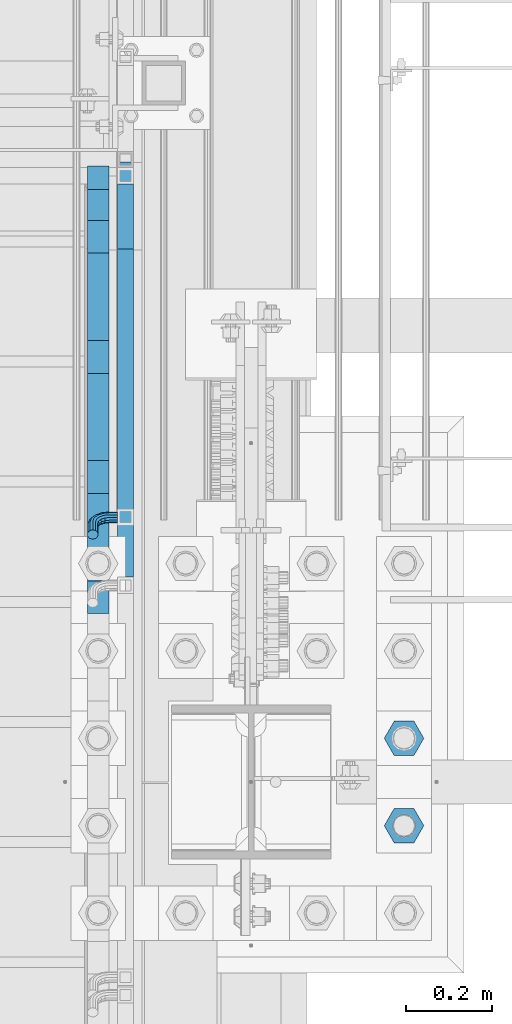
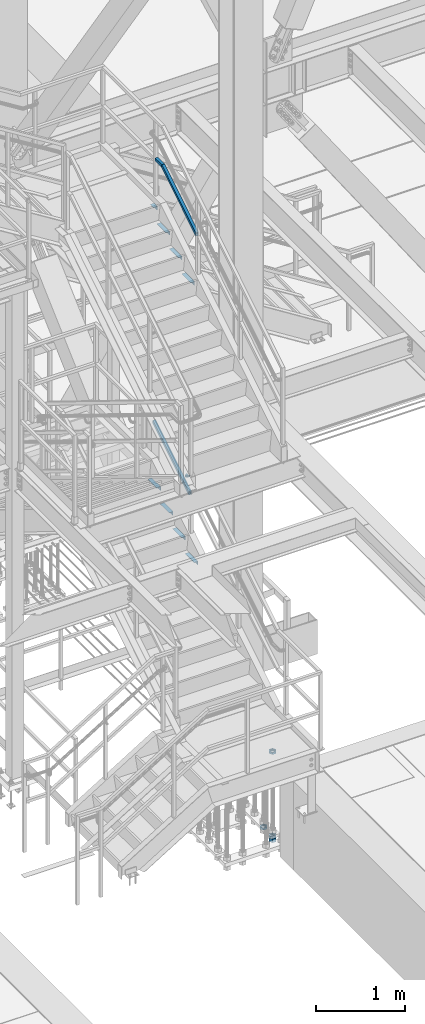
# One storey, part 2094 of 3843: 14 beams, 2 members, 5 elements without a shape of their own.
"""IFC2X3 building model written with IfcOpenShell, lengths in millimetres."""

from ifc_helpers import new_model, si_unit, frame, origin_with_axes, place, context, subcontext, project, spatial, faceted_brep, material, type_object, element, aggregate, save


model = new_model("IFC2X3")

# Units and contexts
model_context = context("Model", 3, precision=1e-05, world=origin_with_axes())
body_context = subcontext(model_context, "Body", "Model", "MODEL_VIEW")
ifc_project = project(units=[si_unit("LENGTHUNIT", "METRE", prefix="MILLI"), si_unit("AREAUNIT", "SQUARE_METRE"), si_unit("VOLUMEUNIT", "CUBIC_METRE"), si_unit("MASSUNIT", "GRAM", prefix="KILO"), si_unit("TIMEUNIT", "SECOND"), si_unit("PLANEANGLEUNIT", "RADIAN"), si_unit("SOLIDANGLEUNIT", "STERADIAN"), si_unit("THERMODYNAMICTEMPERATUREUNIT", "DEGREE_CELSIUS"), si_unit("LUMINOUSINTENSITYUNIT", "LUMEN")], contexts=[model_context])

# Site, building, storey
site_placement = place(None, origin_with_axes())
site = spatial("IfcSite", under=ifc_project, at=site_placement, CompositionType="ELEMENT")
building_placement = place(site_placement, origin_with_axes())
building = spatial("IfcBuilding", under=site, at=building_placement, Name="Undefined", CompositionType="ELEMENT")
storey_placement = place(building_placement, origin_with_axes())
storey = spatial("IfcBuildingStorey", under=building, at=storey_placement, Name="Undefined", CompositionType="ELEMENT", Elevation=0.0)

# Assembly, beam, member
assembly_1_placement = place(storey_placement, origin_with_axes())
assembly_1 = element("IfcElementAssembly", 1, at=assembly_1_placement, inside=storey, Name="RAIL", AssemblyPlace="NOTDEFINED", PredefinedType="RIGID_FRAME")
ifc_material_1 = material()
beam_type_1 = type_object("IfcBeamType", Name="HSS1-1/2X1-1/2X1/4", PredefinedType="NOTDEFINED")
beam_1_placement = place(assembly_1_placement, frame((55638.7, 21551.9000000515, 37227.933331298), z_axis=(0.0, 0.0, 1.0), x_axis=(0.0, 1.0, 0.0)))
beam_1 = element("IfcBeam", 2, at=beam_1_placement, type_object=beam_type_1, material=ifc_material_1, Name="RAIL", ObjectType="HSS1-1/2X1-1/2X1/4", context=body_context, shape_type="Brep", body=[
    faceted_brep([(3.63856705471699, 12.6999993300014, -12.6999993299978), (3.63856705471699, -12.6999993300014, -12.6999993299978), (146.049999950203, -12.6999993299978, -12.6999993299978), (146.049999950203, 12.6999993299978, -12.6999993299978), (-3.6385670492964, -12.6999993300014, 12.6999993299978), (146.049999950203, -12.6999993299978, 12.6999993299978), (-3.6385670492964, 12.6999993300014, 12.6999993299978), (146.049999950203, 12.6999993299978, 12.6999993299978), (5.45785064947268, 19.0499992350015, -19.0499992350015), (-5.45785064405936, 19.0499992350015, 19.0499992350015), (146.049999950203, 19.0499992350015, 19.0499992350015), (146.049999950203, 19.0499992350015, -19.0499992350015), (-5.45785064405936, -19.0499992350015, 19.0499992350015), (146.049999950203, -19.0499992350015, 19.0499992350015), (5.45785064947268, -19.0499992350015, -19.0499992350015), (146.049999950203, -19.0499992350015, -19.0499992350015)], [[[0, 1, 2, 3]], [[1, 4, 5, 2]], [[4, 6, 7, 5]], [[6, 0, 3, 7]], [[8, 9, 10, 11]], [[9, 12, 13, 10]], [[12, 14, 15, 13]], [[14, 8, 11, 15]], [[13, 15, 11, 10], [5, 7, 3, 2]], [[14, 12, 9, 8], [6, 4, 1, 0]]]),
])
member_type = type_object("IfcMemberType", Name="HSS1-1/2X1-1/2X1/4", PredefinedType="NOTDEFINED")
member_1_placement = place(assembly_1_placement, frame((55638.6999999934, 20764.5000000044, 36736.4048464868), z_axis=(0.0, -0.529536736899111, 0.848287005838379), x_axis=(0.0, 0.848287005838377, 0.529536736899114)))
member_1 = element("IfcMember", 3, at=member_1_placement, type_object=member_type, material=ifc_material_1, Name="RAIL", ObjectType="HSS1-1/2X1-1/2X1/4", context=body_context, shape_type="Brep", body=[
    faceted_brep([(14.5291436874832, 12.6999993300014, -12.6999993299687), (14.5291436874832, -12.6999993300014, -12.6999993299687), (924.5850113216, -12.6999993299978, -12.6999993328427), (924.5850113216, 12.6999993299978, -12.6999993328427), (30.3849004243275, -12.6999993300014, 12.6999993299178), (931.862145429259, -12.6999993299978, 12.6999993270983), (30.3849004243275, 12.6999993300014, 12.6999993299178), (931.862145429259, 12.6999993299978, 12.6999993270983), (10.5652043534537, 19.0499992350015, -19.0499992349432), (34.3488397583606, 19.0499992350015, 19.0499992348923), (933.681429024924, 19.0499992350015, 19.0499992320802), (922.765727725928, 19.0499992350015, -19.0499992378245), (34.3488397583606, -19.0499999999956, 19.0499992348923), (933.681429024924, -19.0499992350015, 19.0499992320802), (10.5652043534537, -19.0499992350015, -19.0499992349432), (922.765727725928, -19.0499992350015, -19.0499992378245)], [[[0, 1, 2, 3]], [[1, 4, 5, 2]], [[4, 6, 7, 5]], [[6, 0, 3, 7]], [[8, 9, 10, 11]], [[9, 12, 13, 10]], [[12, 14, 15, 13]], [[14, 8, 11, 15]], [[13, 15, 11, 10], [5, 7, 3, 2]], [[12, 9, 8, 14], [4, 1, 0, 6]]]),
])
aggregate(assembly_1, [beam_1, member_1])

# Assembly, member
assembly_2_placement = place(storey_placement, origin_with_axes())
assembly_2 = element("IfcElementAssembly", 4, at=assembly_2_placement, inside=storey, Name="RAIL", AssemblyPlace="NOTDEFINED", PredefinedType="RIGID_FRAME")
member_2_placement = place(assembly_2_placement, frame((55638.6999999946, 20923.2500000083, 33080.5692295332), z_axis=(0.0, -0.524097425050603, 0.851658317082225), x_axis=(0.0, 0.851658317082228, 0.524097425050598)))
member_2 = element("IfcMember", 5, at=member_2_placement, type_object=member_type, material=ifc_material_1, Name="RAIL", ObjectType="HSS1-1/2X1-1/2X1/4", context=body_context, shape_type="Brep", body=[
    faceted_brep([(973.146838834742, -12.6999993300014, -12.6999993294648), (973.146838834742, 12.6999993300014, -12.6999993294648), (14.5527402998268, 12.6999993300014, -12.6999993299833), (14.5527402998268, -12.6999993300014, -12.6999993299833), (980.336110098666, -12.6999993300014, 12.6999993305053), (30.1835087105574, -12.6999993300014, 12.6999993299978), (980.336110098666, 12.6999993300014, 12.6999993305053), (30.1835087105574, 12.6999993300014, 12.6999993299978), (982.133427982568, 19.0499992350015, 19.0499992355053), (971.349520950855, 19.0499992350015, -19.0499992344648), (10.6450480494532, 19.0499992350015, -19.0499992349796), (34.091200960931, 19.0499992350015, 19.0499992349942), (982.133427982568, -19.0499992350015, 19.0499992355053), (34.091200960931, -19.0499992350015, 19.0499992349942), (971.349520950855, -19.0499992350015, -19.0499992344648), (10.6450480494532, -19.0499992350015, -19.0499992349796)], [[[0, 1, 2, 3]], [[4, 0, 3, 5]], [[6, 4, 5, 7]], [[1, 6, 7, 2]], [[8, 9, 10, 11]], [[12, 8, 11, 13]], [[14, 12, 13, 15]], [[9, 14, 15, 10]], [[12, 14, 9, 8], [4, 6, 1, 0]], [[15, 13, 11, 10], [7, 5, 3, 2]]]),
])

# Assembly, beams
assembly_3_placement = place(storey_placement, origin_with_axes())
assembly_3 = element("IfcElementAssembly", 6, at=assembly_3_placement, inside=storey, Name="STAIR", AssemblyPlace="NOTDEFINED", PredefinedType="RIGID_FRAME")
ifc_material_2 = material(Name="STEEL/A36")
beam_type_2 = type_object("IfcBeamType", Name="L2X2X3/16", PredefinedType="NOTDEFINED")
beam_2_placement = place(assembly_3_placement, frame((55575.2000001424, 21685.2499999968, 36618.33333128), z_axis=(-1.0, 0.0, 0.0), x_axis=(0.0, -1.0, 0.0)))
beam_2 = element("IfcBeam", 7, at=beam_2_placement, type_object=beam_type_2, material=ifc_material_2, Name="ANGLE", ObjectType="L2X2X3/16", context=body_context, shape_type="Brep", body=[
    faceted_brep([(0.0, 25.4000000000015, -25.4000000000015), (0.0, 25.4000000000015, 25.4000000000015), (71.9434500455318, 25.4000000000015, 25.4000000000015), (71.9434500455318, 25.4000000000015, -25.4000000000015), (0.0, 20.6375000000007, 25.4000000000015), (71.9434500455318, 20.6374999999971, 25.4000000000015), (0.0, 20.6375000000007, -20.6375000000007), (71.9434500455318, 20.6374999999971, -20.6374999999971), (0.0, -25.4000000000015, -20.6375000000007), (71.9434500455318, -25.4000000000015, -20.6374999999971), (0.0, -25.4000000000015, -25.4000000000015), (71.9434500455318, -25.4000000000015, -25.4000000000015)], [[[0, 1, 2, 3]], [[1, 4, 5, 2]], [[4, 6, 7, 5]], [[6, 8, 9, 7]], [[8, 10, 11, 9]], [[10, 0, 3, 11]], [[5, 7, 9, 11, 3, 2]], [[10, 8, 6, 4, 1, 0]]]),
])
beam_3_placement = place(assembly_3_placement, frame((55575.2000001424, 21537.1065499542, 36440.7449978634), z_axis=(-1.0, 0.0, 0.0), x_axis=(0.0, -1.0, 0.0)))
beam_3 = element("IfcBeam", 8, at=beam_3_placement, type_object=beam_type_2, material=ifc_material_2, Name="ANGLE", ObjectType="L2X2X3/16", context=body_context, shape_type="Brep", body=[
    faceted_brep([(0.0, 25.4000000000015, -25.4000000000015), (0.0, 25.4000000000015, 25.4000000000015), (203.199999999997, 25.4000000000015, 25.4000000000015), (203.199999999997, 25.4000000000015, -25.4000000000015), (0.0, 20.6375000000007, 25.4000000000015), (203.199999999997, 20.6375000000007, 25.4000000000015), (0.0, 20.6375000000007, -20.6375000000007), (203.199999999997, 20.6375000000007, -20.6375000000007), (0.0, -25.4000000000015, -20.6375000000007), (203.199999999997, -25.4000000000015, -20.6375000000007), (0.0, -25.4000000000015, -25.4000000000015), (203.199999999997, -25.4000000000015, -25.4000000000015)], [[[0, 1, 2, 3]], [[1, 4, 5, 2]], [[4, 6, 7, 5]], [[6, 8, 9, 7]], [[8, 10, 11, 9]], [[10, 0, 3, 11]], [[5, 7, 9, 11, 3, 2]], [[10, 8, 6, 4, 1, 0]]]),
])
beam_4_placement = place(assembly_3_placement, frame((55575.2000001424, 21257.7065499538, 36266.3316644307), z_axis=(-1.0, 0.0, 0.0), x_axis=(0.0, -1.0, 0.0)))
beam_4 = element("IfcBeam", 9, at=beam_4_placement, type_object=beam_type_2, material=ifc_material_2, Name="ANGLE", ObjectType="L2X2X3/16", context=body_context, shape_type="Brep", body=[
    faceted_brep([(0.0, 25.4000000000015, -25.4000000000015), (0.0, 25.4000000000015, 25.4000000000015), (203.199999999997, 25.4000000000015, 25.4000000000015), (203.199999999997, 25.4000000000015, -25.4000000000015), (0.0, 20.6375000000007, 25.4000000000015), (203.199999999997, 20.6375000000007, 25.4000000000015), (0.0, 20.6375000000007, -20.6375000000007), (203.199999999997, 20.6375000000007, -20.6375000000007), (0.0, -25.4000000000015, -20.6375000000007), (203.199999999997, -25.4000000000015, -20.6375000000007), (0.0, -25.4000000000015, -25.4000000000015), (203.199999999997, -25.4000000000015, -25.4000000000015)], [[[0, 1, 2, 3]], [[1, 4, 5, 2]], [[4, 6, 7, 5]], [[6, 8, 9, 7]], [[8, 10, 11, 9]], [[10, 0, 3, 11]], [[5, 7, 9, 11, 3, 2]], [[10, 8, 6, 4, 1, 0]]]),
])
beam_5_placement = place(assembly_3_placement, frame((55575.2000001424, 20978.3065499534, 36091.918330998), z_axis=(-1.0, 0.0, 0.0), x_axis=(0.0, -1.0, 0.0)))
beam_5 = element("IfcBeam", 10, at=beam_5_placement, type_object=beam_type_2, material=ifc_material_2, Name="ANGLE", ObjectType="L2X2X3/16", context=body_context, shape_type="Brep", body=[
    faceted_brep([(0.0, 25.4000000000015, -25.4000000000015), (0.0, 25.4000000000015, 25.4000000000015), (203.199999999997, 25.4000000000015, 25.4000000000015), (203.199999999997, 25.4000000000015, -25.4000000000015), (0.0, 20.6375000000007, 25.4000000000015), (203.199999999997, 20.6375000000007, 25.4000000000015), (0.0, 20.6375000000007, -20.6375000000007), (203.199999999997, 20.6375000000007, -20.6375000000007), (0.0, -25.4000000000015, -20.6375000000007), (203.199999999997, -25.4000000000015, -20.6375000000007), (0.0, -25.4000000000015, -25.4000000000015), (203.199999999997, -25.4000000000015, -25.4000000000015)], [[[0, 1, 2, 3]], [[1, 4, 5, 2]], [[4, 6, 7, 5]], [[6, 8, 9, 7]], [[8, 10, 11, 9]], [[10, 0, 3, 11]], [[5, 7, 9, 11, 3, 2]], [[10, 8, 6, 4, 1, 0]]]),
])
aggregate(assembly_3, [beam_2, beam_3, beam_4, beam_5])

assembly_4_placement = place(storey_placement, origin_with_axes())
assembly_4 = element("IfcElementAssembly", 11, at=assembly_4_placement, inside=storey, Name="STAIR", AssemblyPlace="NOTDEFINED", PredefinedType="RIGID_FRAME")
beam_6_placement = place(assembly_4_placement, frame((55575.1999998292, 21740.4140030453, 32807.7634598906), z_axis=(-1.0, 0.0, 0.0), x_axis=(0.0, -1.0, 0.0)))
beam_6 = element("IfcBeam", 12, at=beam_6_placement, type_object=beam_type_2, material=ifc_material_2, Name="ANGLE", ObjectType="L2X2X3/16", context=body_context, shape_type="Brep", body=[
    faceted_brep([(0.0, 25.4000000000015, -25.4000000000015), (0.0, 25.4000000000015, 25.4000000000015), (203.199999999997, 25.4000000000015, 25.4000000000015), (203.199999999997, 25.4000000000015, -25.4000000000015), (0.0, 20.6375000000007, 25.4000000000015), (203.199999999997, 20.6375000000007, 25.4000000000015), (0.0, 20.6375000000007, -20.6375000000007), (203.199999999997, 20.6375000000007, -20.6375000000007), (0.0, -25.4000000000015, -20.6375000000007), (203.199999999997, -25.4000000000015, -20.6375000000007), (0.0, -25.4000000000015, -25.4000000000015), (203.199999999997, -25.4000000000015, -25.4000000000015)], [[[0, 1, 2, 3]], [[1, 4, 5, 2]], [[4, 6, 7, 5]], [[6, 8, 9, 7]], [[8, 10, 11, 9]], [[10, 0, 3, 11]], [[5, 7, 9, 11, 3, 2]], [[10, 8, 6, 4, 1, 0]]]),
])
beam_7_placement = place(assembly_4_placement, frame((55575.1999998292, 21461.0140030462, 32635.8249984695), z_axis=(-1.0, 0.0, 0.0), x_axis=(0.0, -1.0, 0.0)))
beam_7 = element("IfcBeam", 13, at=beam_7_placement, type_object=beam_type_2, material=ifc_material_2, Name="ANGLE", ObjectType="L2X2X3/16", context=body_context, shape_type="Brep", body=[
    faceted_brep([(0.0, 25.4000000000015, -25.4000000000015), (0.0, 25.4000000000015, 25.4000000000015), (203.199999999997, 25.4000000000015, 25.4000000000015), (203.199999999997, 25.4000000000015, -25.4000000000015), (0.0, 20.6375000000007, 25.4000000000015), (203.199999999997, 20.6375000000007, 25.4000000000015), (0.0, 20.6375000000007, -20.6375000000007), (203.199999999997, 20.6375000000007, -20.6375000000007), (0.0, -25.4000000000015, -20.6375000000007), (203.199999999997, -25.4000000000015, -20.6375000000007), (0.0, -25.4000000000015, -25.4000000000015), (203.199999999997, -25.4000000000015, -25.4000000000015)], [[[0, 1, 2, 3]], [[1, 4, 5, 2]], [[4, 6, 7, 5]], [[6, 8, 9, 7]], [[8, 10, 11, 9]], [[10, 0, 3, 11]], [[5, 7, 9, 11, 3, 2]], [[10, 8, 6, 4, 1, 0]]]),
])
beam_8_placement = place(assembly_4_placement, frame((55575.1999998292, 21181.6140030462, 32463.8865370495), z_axis=(-1.0, 0.0, 0.0), x_axis=(0.0, -1.0, 0.0)))
beam_8 = element("IfcBeam", 14, at=beam_8_placement, type_object=beam_type_2, material=ifc_material_2, Name="ANGLE", ObjectType="L2X2X3/16", context=body_context, shape_type="Brep", body=[
    faceted_brep([(0.0, 25.4000000000015, -25.4000000000015), (0.0, 25.4000000000015, 25.4000000000015), (203.199999999997, 25.4000000000015, 25.4000000000015), (203.199999999997, 25.4000000000015, -25.4000000000015), (0.0, 20.6375000000007, 25.4000000000015), (203.199999999997, 20.6375000000007, 25.4000000000015), (0.0, 20.6375000000007, -20.6375000000007), (203.199999999997, 20.6375000000007, -20.6375000000007), (0.0, -25.4000000000015, -20.6375000000007), (203.199999999997, -25.4000000000015, -20.6375000000007), (0.0, -25.4000000000015, -25.4000000000015), (203.199999999997, -25.4000000000015, -25.4000000000015)], [[[0, 1, 2, 3]], [[1, 4, 5, 2]], [[4, 6, 7, 5]], [[6, 8, 9, 7]], [[8, 10, 11, 9]], [[10, 0, 3, 11]], [[5, 7, 9, 11, 3, 2]], [[10, 8, 6, 4, 1, 0]]]),
])
beam_9_placement = place(assembly_4_placement, frame((55575.1999998292, 20902.2140030456, 32291.9480756294), z_axis=(-1.0, 0.0, 0.0), x_axis=(0.0, -1.0, 0.0)))
beam_9 = element("IfcBeam", 15, at=beam_9_placement, type_object=beam_type_2, material=ifc_material_2, Name="ANGLE", ObjectType="L2X2X3/16", context=body_context, shape_type="Brep", body=[
    faceted_brep([(0.0, 25.4000000000015, -25.4000000000015), (0.0, 25.4000000000015, 25.4000000000015), (203.199999999997, 25.4000000000015, 25.4000000000015), (203.199999999997, 25.4000000000015, -25.4000000000015), (0.0, 20.6375000000007, 25.4000000000015), (203.199999999997, 20.6375000000007, 25.4000000000015), (0.0, 20.6375000000007, -20.6375000000007), (203.199999999997, 20.6375000000007, -20.6375000000007), (0.0, -25.4000000000015, -20.6375000000007), (203.199999999997, -25.4000000000015, -20.6375000000007), (0.0, -25.4000000000015, -25.4000000000015), (203.199999999997, -25.4000000000015, -25.4000000000015)], [[[0, 1, 2, 3]], [[1, 4, 5, 2]], [[4, 6, 7, 5]], [[6, 8, 9, 7]], [[8, 10, 11, 9]], [[10, 0, 3, 11]], [[5, 7, 9, 11, 3, 2]], [[10, 8, 6, 4, 1, 0]]]),
])
aggregate(assembly_4, [beam_6, beam_7, beam_8, beam_9])

assembly_5_placement = place(storey_placement, origin_with_axes())
assembly_5 = element("IfcElementAssembly", 16, at=assembly_5_placement, inside=storey, Name="TEMPLATE", AssemblyPlace="NOTDEFINED", PredefinedType="RIGID_FRAME")
ifc_material_3 = material(Name="STEEL/A572-50")
beam_type_3 = type_object("IfcBeamType", Name="2_HALF_NUT", PredefinedType="NOTDEFINED")
beam_10_placement = place(assembly_5_placement, frame((56286.4, 20408.9, 28613.0999969482), z_axis=(0.0, 1.0, 0.0), x_axis=(0.0, 0.0, -1.0)))
beam_10 = element("IfcBeam", 17, at=beam_10_placement, type_object=beam_type_3, material=ifc_material_3, Name="NUT", ObjectType="2_HALF_NUT", context=body_context, shape_type="Brep", body=[
    faceted_brep([(0.0, -46.0369987487793, 0.0), (0.0, -23.0184993743896, -39.869213104248), (25.4000000000015, -23.0184993743896, -39.869213104248), (25.4000000000015, -46.0369987487793, 0.0), (0.0, 23.0184993743896, -39.869213104248), (25.4000000000015, 23.0184993743896, -39.869213104248), (0.0, 46.0369987487793, 0.0), (25.4000000000015, 46.0369987487793, 0.0), (0.0, 23.0184993743896, 39.869213104248), (25.4000000000015, 23.0184993743896, 39.869213104248), (0.0, -23.0184993743896, 39.869213104248), (25.4000000000015, -23.0184993743896, 39.869213104248), (0.0, 0.0, 26.1940002441406), (0.0, 11.3650617044477, 23.5999013092805), (25.4000000000015, 11.3650617044477, 23.5999013092805), (25.4000000000015, 0.0, 26.1940002441406), (0.0, 20.4791109456419, 16.3316083006721), (25.4000000000015, 20.4791109456419, 16.3316083006721), (0.0, 25.5370200498292, 5.82867859874386), (25.4000000000015, 25.5370200498292, 5.82867859874386), (0.0, 25.5370200498292, -5.82867859874386), (25.4000000000015, 25.5370200498292, -5.82867859874386), (0.0, 20.4791109456419, -16.3316083006721), (25.4000000000015, 20.4791109456419, -16.3316083006721), (0.0, 11.3650617044477, -23.5999013092805), (25.4000000000015, 11.3650617044477, -23.5999013092805), (0.0, 0.0, -26.1940002441406), (25.4000000000015, 0.0, -26.1940002441406), (0.0, -11.3650617044477, -23.5999013092805), (25.4000000000015, -11.3650617044477, -23.5999013092805), (0.0, -20.4791109456419, -16.3316083006721), (25.4000000000015, -20.4791109456419, -16.3316083006721), (0.0, -25.5370200498292, -5.82867859874386), (25.4000000000015, -25.5370200498292, -5.82867859874386), (0.0, -25.5370200498292, 5.82867859874386), (25.4000000000015, -25.5370200498292, 5.82867859874386), (0.0, -20.4791109456419, 16.3316083006721), (25.4000000000015, -20.4791109456419, 16.3316083006721), (0.0, -11.3650617044477, 23.5999013092805), (25.4000000000015, -11.3650617044477, 23.5999013092805)], [[[0, 1, 2, 3]], [[1, 4, 5, 2]], [[4, 6, 7, 5]], [[6, 8, 9, 7]], [[8, 10, 11, 9]], [[10, 0, 3, 11]], [[12, 13, 14, 15]], [[13, 16, 17, 14]], [[16, 18, 19, 17]], [[18, 20, 21, 19]], [[20, 22, 23, 21]], [[22, 24, 25, 23]], [[24, 26, 27, 25]], [[26, 28, 29, 27]], [[28, 30, 31, 29]], [[30, 32, 33, 31]], [[32, 34, 35, 33]], [[34, 36, 37, 35]], [[36, 38, 39, 37]], [[38, 12, 15, 39]], [[5, 7, 9, 11, 3, 2], [17, 19, 21, 23, 25, 27, 29, 31, 33, 35, 37, 39, 15, 14]], [[10, 8, 6, 4, 1, 0], [38, 36, 34, 32, 30, 28, 26, 24, 22, 20, 18, 16, 13, 12]]]),
])
beam_11_placement = place(assembly_5_placement, frame((56286.4, 20205.7, 29775.15), z_axis=(0.0, 1.0, 0.0), x_axis=(0.0, 0.0, -1.0)))
beam_11 = element("IfcBeam", 18, at=beam_11_placement, type_object=beam_type_3, material=ifc_material_3, Name="NUT", ObjectType="2_HALF_NUT", context=body_context, shape_type="Brep", body=[
    faceted_brep([(0.0, -46.0369987487793, 0.0), (0.0, -23.0184993743896, -39.869213104248), (25.4000000000015, -23.0184993743896, -39.869213104248), (25.4000000000015, -46.0369987487793, 0.0), (0.0, 23.0184993743896, -39.869213104248), (25.4000000000015, 23.0184993743896, -39.869213104248), (0.0, 46.0369987487793, 0.0), (25.4000000000015, 46.0369987487793, 0.0), (0.0, 23.0184993743896, 39.869213104248), (25.4000000000015, 23.0184993743896, 39.869213104248), (0.0, -23.0184993743896, 39.869213104248), (25.4000000000015, -23.0184993743896, 39.869213104248), (0.0, 0.0, 26.1940002441406), (0.0, 11.3650617044477, 23.5999013092805), (25.4000000000015, 11.3650617044477, 23.5999013092805), (25.4000000000015, 0.0, 26.1940002441406), (0.0, 20.4791109456419, 16.3316083006721), (25.4000000000015, 20.4791109456419, 16.3316083006721), (0.0, 25.5370200498292, 5.82867859874386), (25.4000000000015, 25.5370200498292, 5.82867859874386), (0.0, 25.5370200498292, -5.82867859874386), (25.4000000000015, 25.5370200498292, -5.82867859874386), (0.0, 20.4791109456419, -16.3316083006721), (25.4000000000015, 20.4791109456419, -16.3316083006721), (0.0, 11.3650617044477, -23.5999013092805), (25.4000000000015, 11.3650617044477, -23.5999013092805), (0.0, 0.0, -26.1940002441406), (25.4000000000015, 0.0, -26.1940002441406), (0.0, -11.3650617044477, -23.5999013092805), (25.4000000000015, -11.3650617044477, -23.5999013092805), (0.0, -20.4791109456419, -16.3316083006721), (25.4000000000015, -20.4791109456419, -16.3316083006721), (0.0, -25.5370200498292, -5.82867859874386), (25.4000000000015, -25.5370200498292, -5.82867859874386), (0.0, -25.5370200498292, 5.82867859874386), (25.4000000000015, -25.5370200498292, 5.82867859874386), (0.0, -20.4791109456419, 16.3316083006721), (25.4000000000015, -20.4791109456419, 16.3316083006721), (0.0, -11.3650617044477, 23.5999013092805), (25.4000000000015, -11.3650617044477, 23.5999013092805)], [[[0, 1, 2, 3]], [[1, 4, 5, 2]], [[4, 6, 7, 5]], [[6, 8, 9, 7]], [[8, 10, 11, 9]], [[10, 0, 3, 11]], [[12, 13, 14, 15]], [[13, 16, 17, 14]], [[16, 18, 19, 17]], [[18, 20, 21, 19]], [[20, 22, 23, 21]], [[22, 24, 25, 23]], [[24, 26, 27, 25]], [[26, 28, 29, 27]], [[28, 30, 31, 29]], [[30, 32, 33, 31]], [[32, 34, 35, 33]], [[34, 36, 37, 35]], [[36, 38, 39, 37]], [[38, 12, 15, 39]], [[5, 7, 9, 11, 3, 2], [17, 19, 21, 23, 25, 27, 29, 31, 33, 35, 37, 39, 15, 14]], [[10, 8, 6, 4, 1, 0], [38, 36, 34, 32, 30, 28, 26, 24, 22, 20, 18, 16, 13, 12]]]),
])
beam_12_placement = place(assembly_5_placement, frame((56286.4, 20205.7, 28613.0999969482), z_axis=(0.0, 1.0, 0.0), x_axis=(0.0, 0.0, -1.0)))
beam_12 = element("IfcBeam", 19, at=beam_12_placement, type_object=beam_type_3, material=ifc_material_3, Name="NUT", ObjectType="2_HALF_NUT", context=body_context, shape_type="Brep", body=[
    faceted_brep([(0.0, -46.0369987487793, 0.0), (0.0, -23.0184993743896, -39.869213104248), (25.4000000000015, -23.0184993743896, -39.869213104248), (25.4000000000015, -46.0369987487793, 0.0), (0.0, 23.0184993743896, -39.869213104248), (25.4000000000015, 23.0184993743896, -39.869213104248), (0.0, 46.0369987487793, 0.0), (25.4000000000015, 46.0369987487793, 0.0), (0.0, 23.0184993743896, 39.869213104248), (25.4000000000015, 23.0184993743896, 39.869213104248), (0.0, -23.0184993743896, 39.869213104248), (25.4000000000015, -23.0184993743896, 39.869213104248), (0.0, 0.0, 26.1940002441406), (0.0, 11.3650617044477, 23.5999013092805), (25.4000000000015, 11.3650617044477, 23.5999013092805), (25.4000000000015, 0.0, 26.1940002441406), (0.0, 20.4791109456419, 16.3316083006721), (25.4000000000015, 20.4791109456419, 16.3316083006721), (0.0, 25.5370200498292, 5.82867859874386), (25.4000000000015, 25.5370200498292, 5.82867859874386), (0.0, 25.5370200498292, -5.82867859874386), (25.4000000000015, 25.5370200498292, -5.82867859874386), (0.0, 20.4791109456419, -16.3316083006721), (25.4000000000015, 20.4791109456419, -16.3316083006721), (0.0, 11.3650617044477, -23.5999013092805), (25.4000000000015, 11.3650617044477, -23.5999013092805), (0.0, 0.0, -26.1940002441406), (25.4000000000015, 0.0, -26.1940002441406), (0.0, -11.3650617044477, -23.5999013092805), (25.4000000000015, -11.3650617044477, -23.5999013092805), (0.0, -20.4791109456419, -16.3316083006721), (25.4000000000015, -20.4791109456419, -16.3316083006721), (0.0, -25.5370200498292, -5.82867859874386), (25.4000000000015, -25.5370200498292, -5.82867859874386), (0.0, -25.5370200498292, 5.82867859874386), (25.4000000000015, -25.5370200498292, 5.82867859874386), (0.0, -20.4791109456419, 16.3316083006721), (25.4000000000015, -20.4791109456419, 16.3316083006721), (0.0, -11.3650617044477, 23.5999013092805), (25.4000000000015, -11.3650617044477, 23.5999013092805)], [[[0, 1, 2, 3]], [[1, 4, 5, 2]], [[4, 6, 7, 5]], [[6, 8, 9, 7]], [[8, 10, 11, 9]], [[10, 0, 3, 11]], [[12, 13, 14, 15]], [[13, 16, 17, 14]], [[16, 18, 19, 17]], [[18, 20, 21, 19]], [[20, 22, 23, 21]], [[22, 24, 25, 23]], [[24, 26, 27, 25]], [[26, 28, 29, 27]], [[28, 30, 31, 29]], [[30, 32, 33, 31]], [[32, 34, 35, 33]], [[34, 36, 37, 35]], [[36, 38, 39, 37]], [[38, 12, 15, 39]], [[5, 7, 9, 11, 3, 2], [17, 19, 21, 23, 25, 27, 29, 31, 33, 35, 37, 39, 15, 14]], [[10, 8, 6, 4, 1, 0], [38, 36, 34, 32, 30, 28, 26, 24, 22, 20, 18, 16, 13, 12]]]),
])
beam_type_4 = type_object("IfcBeamType", Name="2_HEAVY_HEX_NUT", PredefinedType="NOTDEFINED")
beam_13_placement = place(assembly_5_placement, frame((56286.4, 20205.7, 28587.6999969482), z_axis=(0.0, 1.0, 0.0), x_axis=(0.0, 0.0, -1.0)))
beam_13 = element("IfcBeam", 20, at=beam_13_placement, type_object=beam_type_4, material=ifc_material_3, Name="NUT", ObjectType="2_HEAVY_HEX_NUT", context=body_context, shape_type="Brep", body=[
    faceted_brep([(0.0, -46.0369987487793, 0.0), (0.0, -23.0184993743896, -39.869213104248), (50.7999999999993, -23.0184993743896, -39.869213104248), (50.7999999999993, -46.0369987487793, 0.0), (0.0, 23.0184993743896, -39.869213104248), (50.7999999999993, 23.0184993743896, -39.869213104248), (0.0, 46.0369987487793, 0.0), (50.7999999999993, 46.0369987487793, 0.0), (0.0, 23.0184993743896, 39.869213104248), (50.7999999999993, 23.0184993743896, 39.869213104248), (0.0, -23.0184993743896, 39.869213104248), (50.7999999999993, -23.0184993743896, 39.869213104248), (0.0, 0.0, 26.1940002441406), (0.0, 11.3650617044477, 23.5999013092805), (50.7999999999993, 11.3650617044477, 23.5999013092805), (50.7999999999993, 0.0, 26.1940002441406), (0.0, 20.4791109456419, 16.3316083006721), (50.7999999999993, 20.4791109456419, 16.3316083006721), (0.0, 25.5370200498292, 5.82867859874386), (50.7999999999993, 25.5370200498292, 5.82867859874386), (0.0, 25.5370200498292, -5.82867859874386), (50.7999999999993, 25.5370200498292, -5.82867859874386), (0.0, 20.4791109456419, -16.3316083006721), (50.7999999999993, 20.4791109456419, -16.3316083006721), (0.0, 11.3650617044477, -23.5999013092805), (50.7999999999993, 11.3650617044477, -23.5999013092805), (0.0, 0.0, -26.1940002441406), (50.7999999999993, 0.0, -26.1940002441406), (0.0, -11.3650617044477, -23.5999013092805), (50.7999999999993, -11.3650617044477, -23.5999013092805), (0.0, -20.4791109456419, -16.3316083006721), (50.7999999999993, -20.4791109456419, -16.3316083006721), (0.0, -25.5370200498292, -5.82867859874386), (50.7999999999993, -25.5370200498292, -5.82867859874386), (0.0, -25.5370200498292, 5.82867859874386), (50.7999999999993, -25.5370200498292, 5.82867859874386), (0.0, -20.4791109456419, 16.3316083006721), (50.7999999999993, -20.4791109456419, 16.3316083006721), (0.0, -11.3650617044477, 23.5999013092805), (50.7999999999993, -11.3650617044477, 23.5999013092805)], [[[0, 1, 2, 3]], [[1, 4, 5, 2]], [[4, 6, 7, 5]], [[6, 8, 9, 7]], [[8, 10, 11, 9]], [[10, 0, 3, 11]], [[12, 13, 14, 15]], [[13, 16, 17, 14]], [[16, 18, 19, 17]], [[18, 20, 21, 19]], [[20, 22, 23, 21]], [[22, 24, 25, 23]], [[24, 26, 27, 25]], [[26, 28, 29, 27]], [[28, 30, 31, 29]], [[30, 32, 33, 31]], [[32, 34, 35, 33]], [[34, 36, 37, 35]], [[36, 38, 39, 37]], [[38, 12, 15, 39]], [[5, 7, 9, 11, 3, 2], [17, 19, 21, 23, 25, 27, 29, 31, 33, 35, 37, 39, 15, 14]], [[10, 8, 6, 4, 1, 0], [38, 36, 34, 32, 30, 28, 26, 24, 22, 20, 18, 16, 13, 12]]]),
])
aggregate(assembly_5, [beam_10, beam_11, beam_13, beam_12])

# Beam
beam_type_5 = type_object("IfcBeamType", PredefinedType="NOTDEFINED")
beam_14_placement = place(assembly_2_placement, frame((55619.65, 20922.7589967433, 33349.4264450834), z_axis=(0.0, 0.851658317082228, 0.524097425050598), x_axis=(-1.0, 0.0, 0.0)))
beam_14 = element("IfcBeam", 21, at=beam_14_placement, type_object=beam_type_5, material=ifc_material_2, Name="BRACKET ARM", context=body_context, shape_type="Brep", body=[
    faceted_brep([(0.0, -12.6999999999971, 0.0), (0.0, -10.9985226280696, -6.34999999999854), (19.0500015258731, -10.9985226280623, -6.34999999999854), (19.0500015258731, -12.6999999999971, -6.33008312433958e-10), (0.0, -6.35000000000582, -10.9985226280623), (19.0500015258731, -6.34999999999854, -10.9985226280623), (0.0, 0.0, -12.6999999999971), (19.0500015258731, 0.0, -12.6999999999971), (0.0, 6.35000000000582, -10.9985226280623), (19.0500015258731, 6.34999999999854, -10.9985226280623), (0.0, 10.9985226280696, -6.34999999999854), (19.0500015258731, 10.9985226280623, -6.34999999999854), (0.0, 12.6999999999971, 0.0), (19.0500015258731, 12.6999999999971, 0.0), (0.0, 10.9985226280696, 6.34999999999854), (19.0500015258731, 10.9985226280623, 6.34999999999854), (0.0, 6.35000000000582, 10.9985226280623), (19.0500015258731, 6.34999999999854, 10.9985226280623), (0.0, 0.0, 12.6999999999971), (19.0500015258731, 0.0, 12.6999999999971), (0.0, -6.35000000000582, 10.9985226280623), (19.0500015258731, -6.34999999999854, 10.9985226280623), (0.0, -10.9985226280696, 6.34999999999854), (19.0500015258731, -10.9985226280623, 6.34999999999854), (38.4903193060891, -8.8330803677236, -3.34694050252438e-10), (37.8391921052389, -7.26112024908798, 6.34999999974389), (36.0602795104642, -2.96644533684594, 10.9985226280041), (33.6302397149266, 2.90018969451194, 12.7000000002226), (31.2001999194181, 8.76682472604443, 10.9985226285644), (29.4212873247307, 13.061499638774, 6.35000000070431), (28.7701601240115, 14.6334597580644, 7.78527464717627e-10), (29.4212873248762, 13.0614996394288, -6.34999999929278), (31.2001999196509, 8.76682472718676, -10.9985226275603), (33.6302397151885, 2.90018969582889, -12.6999999997788), (36.0602795106824, -2.96644533571089, -10.9985226281206), (37.8391921053699, -7.26112024843314, -6.35000000026048), (53.7678987435793, 3.38210125690239, -6.3499999994383), (54.9710249311902, 2.17897506880399, 5.0931703299284e-10), (50.4808968708676, 6.66910312997061, -10.9985226273784), (45.9907688103704, 11.1592311906061, -12.6999999991458), (41.5006407498004, 15.6493592510378, -10.9985226270364), (38.213638876914, 18.9363611235749, -6.34999999884167), (37.0105126890558, 20.1394873109457, 1.20053300634027e-09), (38.2136388766667, 18.9363611228473, 6.35000000115542), (41.5006407493784, 15.6493592497718, 10.9985226290883), (45.9907688098756, 11.1592311891436, 12.7000000008557), (50.4808968704456, 6.66910312870459, 10.9985226287463), (53.7678987433319, 3.38210125617479, 6.35000000055879), (64.4111202489148, 19.3108078951118, -6.34999999821594), (65.9830803677178, 18.6596806939051, 1.77533365786076e-09), (60.1164453365491, 21.0897204901557, -10.9985226262725), (54.2498103051475, 23.5197602857806, -12.6999999981927), (48.3831752736587, 25.9498000811873, -10.9985226262434), (44.0885003610601, 27.7287126756128, -6.34999999817228), (42.516540241937, 28.3798398759754, 1.83354131877422e-09), (44.08850036074, 27.7287126747688, 6.35000000183209), (48.3831752731057, 25.9498000797321, 10.9985226298813), (54.2498103045073, 23.5197602840999, 12.7000000018088), (60.1164453359961, 21.0897204886933, 10.9985226298522), (64.4111202485947, 19.3108078942678, 6.35000000178115), (68.1485226282239, 38.0999984746086, -6.3499999967753), (69.8499999999913, 38.0999984741211, 2.92493496090174e-09), (63.500000000291, 38.0999984749651, -10.9985226249628), (57.1500000003434, 38.0999984750961, -12.6999999970722), (50.8000000002939, 38.0999984749651, -10.998522625312), (46.1514773720992, 38.0999984746086, -6.34999999737192), (44.4499999999971, 38.0999984741211, 2.58296495303512e-09), (46.1514773717645, 38.0999984736336, 6.35000000262517), (50.7999999996973, 38.0999984732771, 10.9985226308127), (57.1499999996449, 38.0999984731461, 12.700000002922), (63.4999999996944, 38.0999984732771, 10.9985226311619), (68.1485226278892, 38.0999984736336, 6.35000000322179), (68.1485226280638, 76.2000000002372, -6.34999999414867), (69.8499999999913, 76.199999999757, 5.84986992180347e-09), (63.5, 76.200000000601, -10.9985226222125), (57.1499999999942, 76.2000000007247, -12.6999999941472), (50.7999999999884, 76.200000000601, -10.9985226222125), (46.1514773719246, 76.2000000002372, -6.34999999414867), (44.4499999999971, 76.199999999757, 5.84986992180347e-09), (46.1514773719246, 76.1999999992695, 6.35000000584841), (50.7999999999884, 76.1999999989057, 10.9985226339122), (57.1499999999942, 76.199999998782, 12.700000005847), (63.5, 76.1999999989057, 10.9985226339122), (68.1485226280638, 76.1999999992695, 6.35000000584841)], [[[0, 1, 2, 3]], [[1, 4, 5, 2]], [[4, 6, 7, 5]], [[6, 8, 9, 7]], [[8, 10, 11, 9]], [[10, 12, 13, 11]], [[12, 14, 15, 13]], [[14, 16, 17, 15]], [[16, 18, 19, 17]], [[18, 20, 21, 19]], [[20, 22, 23, 21]], [[22, 0, 3, 23]], [[22, 20, 18, 16, 14, 12, 10, 8, 6, 4, 1, 0]], [[23, 3, 24, 25]], [[21, 23, 25, 26]], [[19, 21, 26, 27]], [[17, 19, 27, 28]], [[15, 17, 28, 29]], [[13, 15, 29, 30]], [[11, 13, 30, 31]], [[9, 11, 31, 32]], [[7, 9, 32, 33]], [[5, 7, 33, 34]], [[2, 5, 34, 35]], [[3, 2, 35, 24]], [[35, 36, 37, 24]], [[34, 38, 36, 35]], [[33, 39, 38, 34]], [[32, 40, 39, 33]], [[31, 41, 40, 32]], [[30, 42, 41, 31]], [[29, 43, 42, 30]], [[28, 44, 43, 29]], [[27, 45, 44, 28]], [[26, 46, 45, 27]], [[25, 47, 46, 26]], [[24, 37, 47, 25]], [[36, 48, 49, 37]], [[38, 50, 48, 36]], [[39, 51, 50, 38]], [[40, 52, 51, 39]], [[41, 53, 52, 40]], [[42, 54, 53, 41]], [[43, 55, 54, 42]], [[44, 56, 55, 43]], [[45, 57, 56, 44]], [[46, 58, 57, 45]], [[47, 59, 58, 46]], [[37, 49, 59, 47]], [[48, 60, 61, 49]], [[50, 62, 60, 48]], [[51, 63, 62, 50]], [[52, 64, 63, 51]], [[53, 65, 64, 52]], [[54, 66, 65, 53]], [[55, 67, 66, 54]], [[56, 68, 67, 55]], [[57, 69, 68, 56]], [[58, 70, 69, 57]], [[59, 71, 70, 58]], [[49, 61, 71, 59]], [[61, 60, 72, 73]], [[60, 62, 74, 72]], [[62, 63, 75, 74]], [[63, 64, 76, 75]], [[64, 65, 77, 76]], [[65, 66, 78, 77]], [[66, 67, 79, 78]], [[67, 68, 80, 79]], [[68, 69, 81, 80]], [[69, 70, 82, 81]], [[70, 71, 83, 82]], [[71, 61, 73, 83]], [[74, 75, 76, 77, 78, 79, 80, 81, 82, 83, 73, 72]]]),
])

aggregate(assembly_2, [beam_14, member_2])

save(model, "model.ifc")
